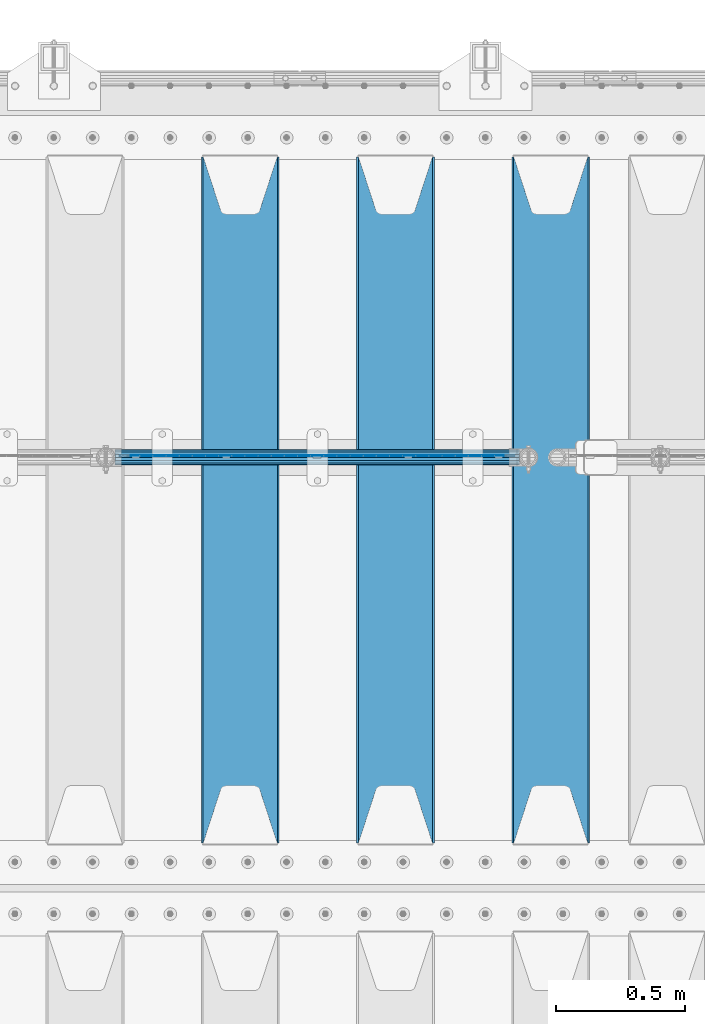
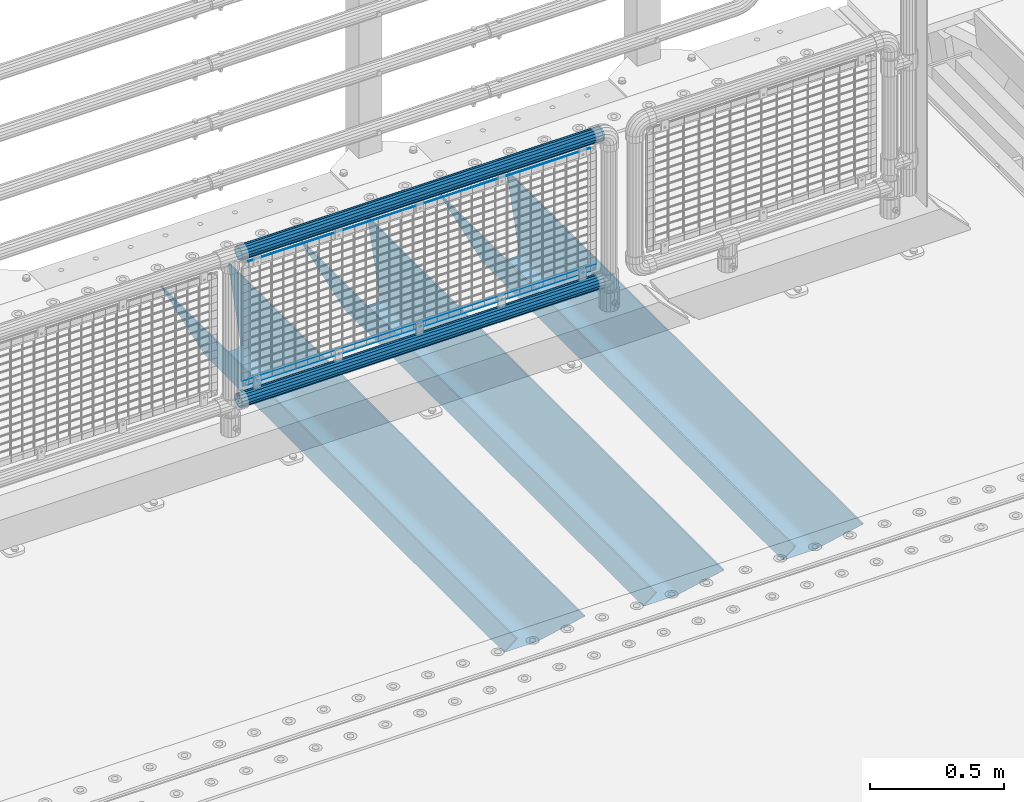
# One storey, part 134 of 242: 8 beams.
"""IFC2X3 building model written with IfcOpenShell, lengths in millimetres."""

from ifc_helpers import new_model, si_unit, frame, origin_with_axes, place, context, subcontext, project, spatial, faceted_brep, material, type_object, element, save


model = new_model("IFC2X3")

# Units and contexts
model_context = context("Model", 3, precision=1e-05, world=origin_with_axes())
body_context = subcontext(model_context, "Body", "Model", "MODEL_VIEW")
ifc_project = project(units=[si_unit("LENGTHUNIT", "METRE", prefix="MILLI"), si_unit("AREAUNIT", "SQUARE_METRE"), si_unit("VOLUMEUNIT", "CUBIC_METRE"), si_unit("MASSUNIT", "GRAM", prefix="KILO"), si_unit("TIMEUNIT", "SECOND"), si_unit("PLANEANGLEUNIT", "RADIAN"), si_unit("SOLIDANGLEUNIT", "STERADIAN"), si_unit("THERMODYNAMICTEMPERATUREUNIT", "DEGREE_CELSIUS"), si_unit("LUMINOUSINTENSITYUNIT", "LUMEN")], contexts=[model_context])

# Site, building, storey
site_placement = place(None, origin_with_axes())
site = spatial("IfcSite", under=ifc_project, at=site_placement, CompositionType="ELEMENT")
building_placement = place(site_placement, origin_with_axes())
building = spatial("IfcBuilding", under=site, at=building_placement, Name="Standard", CompositionType="ELEMENT")
storey_placement = place(building_placement, origin_with_axes())
storey = spatial("IfcBuildingStorey", under=building, at=storey_placement, Name="Undefined", CompositionType="ELEMENT", Elevation=0.0)

# Beams
ifc_material_1 = material(Name="Misc_Undefined")
beam_type_1 = type_object("IfcBeamType", Name="D3", PredefinedType="NOTDEFINED")
beam_1_placement = place(storey_placement, frame((-25419.0, -19329.5, 353.02), z_axis=(0.0, 0.0, 1.0), x_axis=(1.0, 0.0, 0.0)))
element("IfcBeam", 1, at=beam_1_placement, inside=storey, type_object=beam_type_1, material=ifc_material_1, ObjectType="D3", context=body_context, shape_type="Brep", body=[
    faceted_brep([(0.0, -1.50000000000364, 0.0), (-3.63797880709171e-12, -0.750000000003638, -1.29903810567669), (1473.0, -0.75, -1.29903810567669), (1473.0, -1.5, 0.0), (0.0, 0.749999999996362, -1.29903810567669), (1473.0, 0.75, -1.29903810567663), (-3.63797880709171e-12, 1.49999999999636, 0.0), (1473.0, 1.5, 0.0), (0.0, 0.749999999996362, 1.29903810567669), (1473.0, 0.75, 1.29903810567669), (-3.63797880709171e-12, -0.750000000003638, 1.29903810567669), (1473.0, -0.75, 1.29903810567669)], [[[0, 1, 2, 3]], [[1, 4, 5, 2]], [[4, 6, 7, 5]], [[6, 8, 9, 7]], [[8, 10, 11, 9]], [[10, 0, 3, 11]], [[5, 7, 9, 11, 3, 2]], [[10, 8, 6, 4, 1, 0]]]),
])
beam_2_placement = place(storey_placement, frame((-25444.0, -19329.5, 378.02), z_axis=(0.0, 0.0, 1.0), x_axis=(1.0, 0.0, 0.0)))
element("IfcBeam", 2, at=beam_2_placement, inside=storey, type_object=beam_type_1, material=ifc_material_1, ObjectType="D3", context=body_context, shape_type="Brep", body=[
    faceted_brep([(0.0, -1.50000000000364, 0.0), (-3.63797880709171e-12, -0.750000000003638, -1.29903810567669), (1523.0, -0.75, -1.29903810567669), (1523.0, -1.5, 0.0), (0.0, 0.749999999996362, -1.29903810567669), (1523.0, 0.75, -1.29903810567669), (-3.63797880709171e-12, 1.49999999999636, 0.0), (1523.0, 1.5, 0.0), (0.0, 0.749999999996362, 1.29903810567669), (1523.0, 0.75, 1.29903810567669), (-3.63797880709171e-12, -0.750000000003638, 1.29903810567669), (1523.0, -0.75, 1.29903810567669)], [[[0, 1, 2, 3]], [[1, 4, 5, 2]], [[4, 6, 7, 5]], [[6, 8, 9, 7]], [[8, 10, 11, 9]], [[10, 0, 3, 11]], [[5, 7, 9, 11, 3, 2]], [[10, 8, 6, 4, 1, 0]]]),
])
beam_3_placement = place(storey_placement, frame((-25419.0, -19329.5, 913.02), z_axis=(0.0, 0.0, 1.0), x_axis=(1.0, 0.0, 0.0)))
element("IfcBeam", 3, at=beam_3_placement, inside=storey, type_object=beam_type_1, material=ifc_material_1, ObjectType="D3", context=body_context, shape_type="Brep", body=[
    faceted_brep([(0.0, -1.50000000000364, 0.0), (-3.63797880709171e-12, -0.750000000003638, -1.29903810567669), (1473.0, -0.75, -1.29903810567669), (1473.0, -1.5, 0.0), (0.0, 0.749999999996362, -1.29903810567669), (1473.0, 0.75, -1.29903810567663), (-3.63797880709171e-12, 1.49999999999636, 0.0), (1473.0, 1.5, 0.0), (0.0, 0.749999999996362, 1.29903810567669), (1473.0, 0.75, 1.29903810567669), (-3.63797880709171e-12, -0.750000000003638, 1.29903810567669), (1473.0, -0.75, 1.29903810567669)], [[[0, 1, 2, 3]], [[1, 4, 5, 2]], [[4, 6, 7, 5]], [[6, 8, 9, 7]], [[8, 10, 11, 9]], [[10, 0, 3, 11]], [[5, 7, 9, 11, 3, 2]], [[10, 8, 6, 4, 1, 0]]]),
])
ifc_material_2 = material()
beam_type_2 = type_object("IfcBeamType", PredefinedType="NOTDEFINED")
beam_4_placement = place(storey_placement, frame((-25464.15, -19335.5, 969.849999999999), z_axis=(0.0, 0.0, 1.0), x_axis=(1.0, 0.0, 0.0)))
element("IfcBeam", 4, at=beam_4_placement, inside=storey, type_object=beam_type_2, material=ifc_material_2, context=body_context, shape_type="Brep", body=[
    faceted_brep([(0.0, -25.3499999999985, 0.0), (0.0, -23.4203461491597, 9.70102501045403), (1563.0, -23.4203461491597, 9.70102501045506), (1563.0, -25.3499999999985, 0.0), (0.0, -17.9251569030785, 17.9251569030785), (1563.0, -17.9251569030785, 17.925156903079), (0.0, -9.70102501045403, 23.4203461491597), (1563.0, -9.70102501045403, 23.4203461491611), (0.0, 0.0, 25.3499999999985), (1563.0, 0.0, 25.35), (0.0, 9.70102501045403, 23.4203461491597), (1563.0, 9.70102501045403, 23.4203461491611), (0.0, 17.9251569030785, 17.9251569030785), (1563.0, 17.9251569030785, 17.925156903079), (0.0, 23.4203461491597, 9.70102501045403), (1563.0, 23.4203461491597, 9.70102501045506), (0.0, 25.3499999999985, 0.0), (1563.0, 25.3499999999985, 0.0), (0.0, 23.4203461491597, -9.70102501045403), (1563.0, 23.4203461491597, -9.70102501045506), (0.0, 17.9251569030785, -17.9251569030785), (1563.0, 17.9251569030785, -17.925156903079), (0.0, 9.70102501045403, -23.4203461491597), (1563.0, 9.70102501045403, -23.4203461491611), (0.0, 0.0, -25.3499999999985), (1563.0, 0.0, -25.35), (0.0, -9.70102501045403, -23.4203461491597), (1563.0, -9.70102501045403, -23.4203461491611), (0.0, -17.9251569030785, -17.9251569030785), (1563.0, -17.9251569030785, -17.925156903079), (0.0, -23.4203461491597, -9.70102501045403), (1563.0, -23.4203461491597, -9.70102501045506), (0.0, -30.1500000000015, 0.0), (0.0, -27.8549679052157, -11.5379054858058), (1563.0, -27.8549679052157, -11.5379054858075), (1563.0, -30.1500000000015, 0.0), (0.0, -21.3192694527752, -21.3192694527752), (1563.0, -21.3192694527752, -21.3192694527744), (0.0, -11.5379054858058, -27.8549679052157), (1563.0, -11.5379054858058, -27.8549679052153), (0.0, 0.0, -30.1500000000015), (1563.0, 0.0, -30.15), (0.0, 11.5379054858058, -27.8549679052157), (1563.0, 11.5379054858058, -27.8549679052153), (0.0, 21.3192694527752, -21.3192694527752), (1563.0, 21.3192694527752, -21.3192694527744), (0.0, 27.8549679052157, -11.5379054858058), (1563.0, 27.8549679052157, -11.5379054858074), (0.0, 30.1500000000015, 0.0), (1563.0, 30.1500000000015, 0.0), (0.0, 27.8549679052157, 11.5379054858058), (1563.0, 27.8549679052157, 11.5379054858074), (0.0, 21.3192694527752, 21.3192694527752), (1563.0, 21.3192694527752, 21.3192694527744), (0.0, 11.5379054858058, 27.8549679052157), (1563.0, 11.5379054858058, 27.8549679052153), (0.0, 0.0, 30.1500000000015), (1563.0, 0.0, 30.15), (0.0, -11.5379054858058, 27.8549679052157), (1563.0, -11.5379054858058, 27.8549679052153), (0.0, -21.3192694527752, 21.3192694527752), (1563.0, -21.3192694527752, 21.3192694527744), (0.0, -27.8549679052157, 11.5379054858058), (1563.0, -27.8549679052157, 11.5379054858074)], [[[0, 1, 2, 3]], [[1, 4, 5, 2]], [[4, 6, 7, 5]], [[6, 8, 9, 7]], [[8, 10, 11, 9]], [[10, 12, 13, 11]], [[12, 14, 15, 13]], [[14, 16, 17, 15]], [[16, 18, 19, 17]], [[18, 20, 21, 19]], [[20, 22, 23, 21]], [[22, 24, 25, 23]], [[24, 26, 27, 25]], [[26, 28, 29, 27]], [[28, 30, 31, 29]], [[30, 0, 3, 31]], [[32, 33, 34, 35]], [[33, 36, 37, 34]], [[36, 38, 39, 37]], [[38, 40, 41, 39]], [[40, 42, 43, 41]], [[42, 44, 45, 43]], [[44, 46, 47, 45]], [[46, 48, 49, 47]], [[48, 50, 51, 49]], [[50, 52, 53, 51]], [[52, 54, 55, 53]], [[54, 56, 57, 55]], [[56, 58, 59, 57]], [[58, 60, 61, 59]], [[60, 62, 63, 61]], [[62, 32, 35, 63]], [[37, 39, 41, 43, 45, 47, 49, 51, 53, 55, 57, 59, 61, 63, 35, 34], [5, 7, 9, 11, 13, 15, 17, 19, 21, 23, 25, 27, 29, 31, 3, 2]], [[62, 60, 58, 56, 54, 52, 50, 48, 46, 44, 42, 40, 38, 36, 33, 32], [30, 28, 26, 24, 22, 20, 18, 16, 14, 12, 10, 8, 6, 4, 1, 0]]]),
])
beam_5_placement = place(storey_placement, frame((-25464.15, -19335.5, 298.170000000001), z_axis=(0.0, 0.0, 1.0), x_axis=(1.0, 0.0, 0.0)))
element("IfcBeam", 5, at=beam_5_placement, inside=storey, type_object=beam_type_2, material=ifc_material_2, context=body_context, shape_type="Brep", body=[
    faceted_brep([(0.0, -25.3499999999985, 0.0), (0.0, -23.4203461491597, 9.70102501045403), (1563.0, -23.4203461491597, 9.70102501045506), (1563.0, -25.3499999999985, 0.0), (0.0, -17.9251569030785, 17.9251569030785), (1563.0, -17.9251569030785, 17.925156903079), (0.0, -9.70102501045403, 23.4203461491597), (1563.0, -9.70102501045403, 23.4203461491611), (0.0, 0.0, 25.3499999999985), (1563.0, 0.0, 25.35), (0.0, 9.70102501045403, 23.4203461491597), (1563.0, 9.70102501045403, 23.4203461491611), (0.0, 17.9251569030785, 17.9251569030785), (1563.0, 17.9251569030785, 17.925156903079), (0.0, 23.4203461491597, 9.70102501045403), (1563.0, 23.4203461491597, 9.70102501045506), (0.0, 25.3499999999985, 0.0), (1563.0, 25.3499999999985, 0.0), (0.0, 23.4203461491597, -9.70102501045403), (1563.0, 23.4203461491597, -9.70102501045506), (0.0, 17.9251569030785, -17.9251569030785), (1563.0, 17.9251569030785, -17.925156903079), (0.0, 9.70102501045403, -23.4203461491597), (1563.0, 9.70102501045403, -23.4203461491611), (0.0, 0.0, -25.3499999999985), (1563.0, 0.0, -25.35), (0.0, -9.70102501045403, -23.4203461491597), (1563.0, -9.70102501045403, -23.4203461491611), (0.0, -17.9251569030785, -17.9251569030785), (1563.0, -17.9251569030785, -17.925156903079), (0.0, -23.4203461491597, -9.70102501045403), (1563.0, -23.4203461491597, -9.70102501045506), (0.0, -30.1500000000015, 0.0), (0.0, -27.8549679052157, -11.5379054858058), (1563.0, -27.8549679052157, -11.5379054858075), (1563.0, -30.1500000000015, 0.0), (0.0, -21.3192694527752, -21.3192694527752), (1563.0, -21.3192694527752, -21.3192694527744), (0.0, -11.5379054858058, -27.8549679052157), (1563.0, -11.5379054858058, -27.8549679052153), (0.0, 0.0, -30.1500000000015), (1563.0, 0.0, -30.15), (0.0, 11.5379054858058, -27.8549679052157), (1563.0, 11.5379054858058, -27.8549679052153), (0.0, 21.3192694527752, -21.3192694527752), (1563.0, 21.3192694527752, -21.3192694527744), (0.0, 27.8549679052157, -11.5379054858058), (1563.0, 27.8549679052157, -11.5379054858074), (0.0, 30.1500000000015, 0.0), (1563.0, 30.1500000000015, 0.0), (0.0, 27.8549679052157, 11.5379054858058), (1563.0, 27.8549679052157, 11.5379054858074), (0.0, 21.3192694527752, 21.3192694527752), (1563.0, 21.3192694527752, 21.3192694527744), (0.0, 11.5379054858058, 27.8549679052157), (1563.0, 11.5379054858058, 27.8549679052153), (0.0, 0.0, 30.1500000000015), (1563.0, 0.0, 30.15), (0.0, -11.5379054858058, 27.8549679052157), (1563.0, -11.5379054858058, 27.8549679052153), (0.0, -21.3192694527752, 21.3192694527752), (1563.0, -21.3192694527752, 21.3192694527744), (0.0, -27.8549679052157, 11.5379054858058), (1563.0, -27.8549679052157, 11.5379054858074)], [[[0, 1, 2, 3]], [[1, 4, 5, 2]], [[4, 6, 7, 5]], [[6, 8, 9, 7]], [[8, 10, 11, 9]], [[10, 12, 13, 11]], [[12, 14, 15, 13]], [[14, 16, 17, 15]], [[16, 18, 19, 17]], [[18, 20, 21, 19]], [[20, 22, 23, 21]], [[22, 24, 25, 23]], [[24, 26, 27, 25]], [[26, 28, 29, 27]], [[28, 30, 31, 29]], [[30, 0, 3, 31]], [[32, 33, 34, 35]], [[33, 36, 37, 34]], [[36, 38, 39, 37]], [[38, 40, 41, 39]], [[40, 42, 43, 41]], [[42, 44, 45, 43]], [[44, 46, 47, 45]], [[46, 48, 49, 47]], [[48, 50, 51, 49]], [[50, 52, 53, 51]], [[52, 54, 55, 53]], [[54, 56, 57, 55]], [[56, 58, 59, 57]], [[58, 60, 61, 59]], [[60, 62, 63, 61]], [[62, 32, 35, 63]], [[37, 39, 41, 43, 45, 47, 49, 51, 53, 55, 57, 59, 61, 63, 35, 34], [5, 7, 9, 11, 13, 15, 17, 19, 21, 23, 25, 27, 29, 31, 3, 2]], [[62, 60, 58, 56, 54, 52, 50, 48, 46, 44, 42, 40, 38, 36, 33, 32], [30, 28, 26, 24, 22, 20, 18, 16, 14, 12, 10, 8, 6, 4, 1, 0]]]),
])
ifc_material_3 = material(Name="STEEL/S355N")
beam_type_3 = type_object("IfcBeamType", PredefinedType="NOTDEFINED")
beam_6_placement = place(storey_placement, frame((-23780.0, -20825.0, -115.0), z_axis=(0.0, 0.0, 1.0), x_axis=(0.0, 1.0, 0.0)))
element("IfcBeam", 6, at=beam_6_placement, inside=storey, type_object=beam_type_3, material=ifc_material_3, context=body_context, shape_type="Brep", body=[
    faceted_brep([(0.0, 150.0, 115.0), (0.0, 143.689999999999, 115.0), (2650.00000000297, 143.689999999999, 115.0), (2650.00000000297, 150.0, 115.0), (2650.00000000297, 142.059565218402, 110.000000003099), (2650.00000000297, 148.369565218403, 110.000000003099), (2441.90079219209, -80.1103600731112, -98.0992078077845), (2437.7588105432, -77.5672621345584, -102.241189456673), (2434.06523489747, -74.4080125315522, -105.934765102404), (2430.91086095089, -70.710272125576, -109.089139048974), (2428.37322971128, -66.5649389910068, -111.626770288588), (2426.51472138055, -62.0739139532889, -113.485278619323), (2425.38102192092, -57.3475956567672, -114.618978078955), (2424.99999999987, -52.5021667386536, -115.0), (2424.99999999987, 52.5021667386536, -115.0), (2425.38102192092, 57.3475956567672, -114.618978078955), (2426.51472138055, 62.0739139532889, -113.485278619323), (2428.37322971128, 66.5649389910068, -111.626770288588), (2430.91086095089, 70.710272125576, -109.089139048974), (2434.06523489747, 74.4080125315522, -105.934765102404), (2437.7588105432, 77.5672621345584, -102.241189456673), (2441.90079219209, 80.1103600731112, -98.0992078077846), (2446.38936140511, 81.9747917625791, -93.6106385947584), (2448.2494850041, 76.2713538057251, -91.7505149957729), (2444.62967112262, 74.76777986261, -95.3703288772456), (2441.28936334126, 72.7168944282894, -98.710636658607), (2438.31067330438, 70.1691124903846, -101.689326695487), (2435.76682334747, 67.1870637758839, -104.233176652398), (2433.72034654133, 63.8440531834895, -106.279653458539), (2432.22154950042, 60.222258798236, -107.778450499454), (2431.30727574265, 56.4107117849089, -108.692724257221), (2430.99999999987, 52.5031078186876, -109.0), (2430.99999999987, -52.5031078186876, -109.0), (2431.30727574265, -56.4107117849089, -108.692724257221), (2432.22154950042, -60.222258798236, -107.778450499454), (2433.72034654133, -63.8440531834895, -106.279653458539), (2435.76682334747, -67.1870637758839, -104.233176652398), (2438.31067330438, -70.1691124903846, -101.689326695487), (2441.28936334126, -72.7168944282894, -98.7106366586071), (2444.62967112262, -74.76777986261, -95.3703288772457), (2448.2494850041, -76.2713538057251, -91.7505149957729), (2650.00000000297, -142.059565218402, 110.000000003099), (2650.00000000297, -148.369565218403, 110.000000003099), (2446.38936140511, -81.9747917625791, -93.6106385947584), (2650.00000000297, -143.689999999999, 115.0), (2650.00000000297, -150.0, 115.0), (0.0, -143.689999999999, 115.0), (0.0, -150.0, 115.0), (0.0, -148.369565218261, 110.000000002669), (203.610638597427, -81.9747917625791, -93.6106385947584), (208.099207810454, -80.1103600731112, -98.0992078077845), (212.241189459342, -77.5672621345584, -102.241189456673), (215.934765105074, -74.4080125315522, -105.934765102404), (219.089139051644, -70.710272125576, -109.089139048974), (221.626770291256, -66.5649389910068, -111.626770288588), (223.485278621993, -62.0739139532889, -113.485278619323), (224.618978081624, -57.3475956567672, -114.618978078955), (225.00000000267, -52.5021667386536, -115.0), (225.00000000267, 52.5021667386536, -115.0), (224.618978081624, 57.3475956567672, -114.618978078955), (223.485278621993, 62.0739139532889, -113.485278619323), (221.626770291256, 66.5649389910068, -111.626770288588), (219.089139051644, 70.710272125576, -109.089139048974), (215.934765105074, 74.4080125315522, -105.934765102404), (212.241189459342, 77.5672621345584, -102.241189456673), (208.099207810454, 80.1103600731112, -98.0992078077846), (203.610638597427, 81.9747917625791, -93.6106385947584), (0.0, 148.369565218261, 110.000000002669), (0.0, 142.05956521826, 110.000000002669), (201.750514998443, 76.2713538057251, -91.7505149957729), (205.370328879915, 74.76777986261, -95.3703288772456), (208.710636661275, 72.7168944282894, -98.710636658607), (211.689326698157, 70.1691124903846, -101.689326695487), (214.233176655067, 67.1870637758839, -104.233176652398), (216.279653461206, 63.8440531834895, -106.279653458539), (217.778450502123, 60.222258798236, -107.778450499454), (218.69272425989, 56.4107117849089, -108.692724257221), (219.00000000267, 52.5031078186876, -109.0), (219.00000000267, -52.5031078186876, -109.0), (218.69272425989, -56.4107117849089, -108.692724257221), (217.778450502123, -60.222258798236, -107.778450499454), (216.279653461206, -63.8440531834895, -106.279653458539), (214.233176655067, -67.1870637758839, -104.233176652398), (211.689326698157, -70.1691124903846, -101.689326695487), (208.710636661275, -72.7168944282894, -98.7106366586071), (205.370328879915, -74.76777986261, -95.3703288772457), (201.750514998443, -76.2713538057251, -91.7505149957729), (0.0, -142.05956521826, 110.000000002669)], [[[0, 1, 2, 3]], [[3, 2, 4, 5]], [[6, 7, 8, 9, 10, 11, 12, 13, 14, 15, 16, 17, 18, 19, 20, 21, 22, 5, 4, 23, 24, 25, 26, 27, 28, 29, 30, 31, 32, 33, 34, 35, 36, 37, 38, 39, 40, 41, 42, 43]], [[44, 45, 42, 41]], [[46, 47, 45, 44]], [[43, 42, 45, 47, 48, 49]], [[6, 43, 49, 50]], [[7, 6, 50, 51]], [[8, 7, 51, 52]], [[9, 8, 52, 53]], [[10, 9, 53, 54]], [[11, 10, 54, 55]], [[12, 11, 55, 56]], [[13, 12, 56, 57]], [[14, 13, 57, 58]], [[15, 14, 58, 59]], [[16, 15, 59, 60]], [[17, 16, 60, 61]], [[18, 17, 61, 62]], [[19, 18, 62, 63]], [[20, 19, 63, 64]], [[21, 20, 64, 65]], [[22, 21, 65, 66]], [[0, 3, 5, 22, 66, 67]], [[1, 0, 67, 68]], [[23, 4, 2, 1, 68, 69]], [[24, 23, 69, 70]], [[25, 24, 70, 71]], [[26, 25, 71, 72]], [[27, 26, 72, 73]], [[28, 27, 73, 74]], [[29, 28, 74, 75]], [[30, 29, 75, 76]], [[31, 30, 76, 77]], [[32, 31, 77, 78]], [[33, 32, 78, 79]], [[34, 33, 79, 80]], [[35, 34, 80, 81]], [[36, 35, 81, 82]], [[37, 36, 82, 83]], [[38, 37, 83, 84]], [[39, 38, 84, 85]], [[40, 39, 85, 86]], [[46, 44, 41, 40, 86, 87]], [[47, 46, 87, 48]], [[86, 85, 84, 83, 82, 81, 80, 79, 78, 77, 76, 75, 74, 73, 72, 71, 70, 69, 68, 67, 66, 65, 64, 63, 62, 61, 60, 59, 58, 57, 56, 55, 54, 53, 52, 51, 50, 49, 48, 87]]]),
])
beam_7_placement = place(storey_placement, frame((-24380.0, -20825.0, -115.0), z_axis=(0.0, 0.0, 1.0), x_axis=(0.0, 1.0, 0.0)))
element("IfcBeam", 7, at=beam_7_placement, inside=storey, type_object=beam_type_3, material=ifc_material_3, context=body_context, shape_type="Brep", body=[
    faceted_brep([(0.0, 150.0, 115.0), (0.0, 143.689999999999, 115.0), (2650.00000000297, 143.689999999999, 115.0), (2650.00000000297, 150.0, 115.0), (2650.00000000297, 142.059565218402, 110.000000003099), (2650.00000000297, 148.369565218403, 110.000000003099), (2441.90079219209, -80.1103600731112, -98.0992078077845), (2437.7588105432, -77.5672621345584, -102.241189456673), (2434.06523489747, -74.4080125315522, -105.934765102404), (2430.91086095089, -70.710272125576, -109.089139048974), (2428.37322971128, -66.5649389910068, -111.626770288588), (2426.51472138055, -62.0739139532889, -113.485278619323), (2425.38102192092, -57.3475956567672, -114.618978078955), (2424.99999999987, -52.5021667386536, -115.0), (2424.99999999987, 52.5021667386536, -115.0), (2425.38102192092, 57.3475956567672, -114.618978078955), (2426.51472138055, 62.0739139532889, -113.485278619323), (2428.37322971128, 66.5649389910068, -111.626770288588), (2430.91086095089, 70.710272125576, -109.089139048974), (2434.06523489747, 74.4080125315522, -105.934765102404), (2437.7588105432, 77.5672621345584, -102.241189456673), (2441.90079219209, 80.1103600731112, -98.0992078077846), (2446.38936140511, 81.9747917625791, -93.6106385947584), (2448.2494850041, 76.2713538057251, -91.7505149957729), (2444.62967112262, 74.76777986261, -95.3703288772456), (2441.28936334126, 72.7168944282894, -98.710636658607), (2438.31067330438, 70.1691124903846, -101.689326695487), (2435.76682334747, 67.1870637758839, -104.233176652398), (2433.72034654133, 63.8440531834895, -106.279653458539), (2432.22154950042, 60.222258798236, -107.778450499454), (2431.30727574265, 56.4107117849089, -108.692724257221), (2430.99999999987, 52.5031078186876, -109.0), (2430.99999999987, -52.5031078186876, -109.0), (2431.30727574265, -56.4107117849089, -108.692724257221), (2432.22154950042, -60.222258798236, -107.778450499454), (2433.72034654133, -63.8440531834895, -106.279653458539), (2435.76682334747, -67.1870637758839, -104.233176652398), (2438.31067330438, -70.1691124903846, -101.689326695487), (2441.28936334126, -72.7168944282894, -98.7106366586071), (2444.62967112262, -74.76777986261, -95.3703288772457), (2448.2494850041, -76.2713538057251, -91.7505149957729), (2650.00000000297, -142.059565218402, 110.000000003099), (2650.00000000297, -148.369565218403, 110.000000003099), (2446.38936140511, -81.9747917625791, -93.6106385947584), (2650.00000000297, -143.689999999999, 115.0), (2650.00000000297, -150.0, 115.0), (0.0, -143.689999999999, 115.0), (0.0, -150.0, 115.0), (0.0, -148.369565218261, 110.000000002669), (203.610638597427, -81.9747917625791, -93.6106385947584), (208.099207810454, -80.1103600731112, -98.0992078077845), (212.241189459342, -77.5672621345584, -102.241189456673), (215.934765105074, -74.4080125315522, -105.934765102404), (219.089139051644, -70.710272125576, -109.089139048974), (221.626770291256, -66.5649389910068, -111.626770288588), (223.485278621993, -62.0739139532889, -113.485278619323), (224.618978081624, -57.3475956567672, -114.618978078955), (225.00000000267, -52.5021667386536, -115.0), (225.00000000267, 52.5021667386536, -115.0), (224.618978081624, 57.3475956567672, -114.618978078955), (223.485278621993, 62.0739139532889, -113.485278619323), (221.626770291256, 66.5649389910068, -111.626770288588), (219.089139051644, 70.710272125576, -109.089139048974), (215.934765105074, 74.4080125315522, -105.934765102404), (212.241189459342, 77.5672621345584, -102.241189456673), (208.099207810454, 80.1103600731112, -98.0992078077846), (203.610638597427, 81.9747917625791, -93.6106385947584), (0.0, 148.369565218261, 110.000000002669), (0.0, 142.05956521826, 110.000000002669), (201.750514998443, 76.2713538057251, -91.7505149957729), (205.370328879915, 74.76777986261, -95.3703288772456), (208.710636661275, 72.7168944282894, -98.710636658607), (211.689326698157, 70.1691124903846, -101.689326695487), (214.233176655067, 67.1870637758839, -104.233176652398), (216.279653461206, 63.8440531834895, -106.279653458539), (217.778450502123, 60.222258798236, -107.778450499454), (218.69272425989, 56.4107117849089, -108.692724257221), (219.00000000267, 52.5031078186876, -109.0), (219.00000000267, -52.5031078186876, -109.0), (218.69272425989, -56.4107117849089, -108.692724257221), (217.778450502123, -60.222258798236, -107.778450499454), (216.279653461206, -63.8440531834895, -106.279653458539), (214.233176655067, -67.1870637758839, -104.233176652398), (211.689326698157, -70.1691124903846, -101.689326695487), (208.710636661275, -72.7168944282894, -98.7106366586071), (205.370328879915, -74.76777986261, -95.3703288772457), (201.750514998443, -76.2713538057251, -91.7505149957729), (0.0, -142.05956521826, 110.000000002669)], [[[0, 1, 2, 3]], [[3, 2, 4, 5]], [[6, 7, 8, 9, 10, 11, 12, 13, 14, 15, 16, 17, 18, 19, 20, 21, 22, 5, 4, 23, 24, 25, 26, 27, 28, 29, 30, 31, 32, 33, 34, 35, 36, 37, 38, 39, 40, 41, 42, 43]], [[44, 45, 42, 41]], [[46, 47, 45, 44]], [[43, 42, 45, 47, 48, 49]], [[6, 43, 49, 50]], [[7, 6, 50, 51]], [[8, 7, 51, 52]], [[9, 8, 52, 53]], [[10, 9, 53, 54]], [[11, 10, 54, 55]], [[12, 11, 55, 56]], [[13, 12, 56, 57]], [[14, 13, 57, 58]], [[15, 14, 58, 59]], [[16, 15, 59, 60]], [[17, 16, 60, 61]], [[18, 17, 61, 62]], [[19, 18, 62, 63]], [[20, 19, 63, 64]], [[21, 20, 64, 65]], [[22, 21, 65, 66]], [[0, 3, 5, 22, 66, 67]], [[1, 0, 67, 68]], [[23, 4, 2, 1, 68, 69]], [[24, 23, 69, 70]], [[25, 24, 70, 71]], [[26, 25, 71, 72]], [[27, 26, 72, 73]], [[28, 27, 73, 74]], [[29, 28, 74, 75]], [[30, 29, 75, 76]], [[31, 30, 76, 77]], [[32, 31, 77, 78]], [[33, 32, 78, 79]], [[34, 33, 79, 80]], [[35, 34, 80, 81]], [[36, 35, 81, 82]], [[37, 36, 82, 83]], [[38, 37, 83, 84]], [[39, 38, 84, 85]], [[40, 39, 85, 86]], [[46, 44, 41, 40, 86, 87]], [[47, 46, 87, 48]], [[86, 85, 84, 83, 82, 81, 80, 79, 78, 77, 76, 75, 74, 73, 72, 71, 70, 69, 68, 67, 66, 65, 64, 63, 62, 61, 60, 59, 58, 57, 56, 55, 54, 53, 52, 51, 50, 49, 48, 87]]]),
])
beam_8_placement = place(storey_placement, frame((-24980.0, -20825.0, -115.0), z_axis=(0.0, 0.0, 1.0), x_axis=(0.0, 1.0, 0.0)))
element("IfcBeam", 8, at=beam_8_placement, inside=storey, type_object=beam_type_3, material=ifc_material_3, context=body_context, shape_type="Brep", body=[
    faceted_brep([(0.0, 150.0, 115.0), (0.0, 143.689999999999, 115.0), (2650.00000000297, 143.689999999999, 115.0), (2650.00000000297, 150.0, 115.0), (2650.00000000297, 142.059565218402, 110.000000003099), (2650.00000000297, 148.369565218403, 110.000000003099), (2441.90079219209, -80.1103600731112, -98.0992078077845), (2437.7588105432, -77.5672621345584, -102.241189456673), (2434.06523489747, -74.4080125315522, -105.934765102404), (2430.91086095089, -70.710272125576, -109.089139048974), (2428.37322971128, -66.5649389910068, -111.626770288588), (2426.51472138055, -62.0739139532889, -113.485278619323), (2425.38102192092, -57.3475956567672, -114.618978078955), (2424.99999999987, -52.5021667386536, -115.0), (2424.99999999987, 52.5021667386536, -115.0), (2425.38102192092, 57.3475956567672, -114.618978078955), (2426.51472138055, 62.0739139532889, -113.485278619323), (2428.37322971128, 66.5649389910068, -111.626770288588), (2430.91086095089, 70.710272125576, -109.089139048974), (2434.06523489747, 74.4080125315522, -105.934765102404), (2437.7588105432, 77.5672621345584, -102.241189456673), (2441.90079219209, 80.1103600731112, -98.0992078077846), (2446.38936140511, 81.9747917625791, -93.6106385947584), (2448.2494850041, 76.2713538057251, -91.7505149957729), (2444.62967112262, 74.76777986261, -95.3703288772456), (2441.28936334126, 72.7168944282894, -98.710636658607), (2438.31067330438, 70.1691124903846, -101.689326695487), (2435.76682334747, 67.1870637758839, -104.233176652398), (2433.72034654133, 63.8440531834895, -106.279653458539), (2432.22154950042, 60.222258798236, -107.778450499454), (2431.30727574265, 56.4107117849089, -108.692724257221), (2430.99999999987, 52.5031078186876, -109.0), (2430.99999999987, -52.5031078186876, -109.0), (2431.30727574265, -56.4107117849089, -108.692724257221), (2432.22154950042, -60.222258798236, -107.778450499454), (2433.72034654133, -63.8440531834895, -106.279653458539), (2435.76682334747, -67.1870637758839, -104.233176652398), (2438.31067330438, -70.1691124903846, -101.689326695487), (2441.28936334126, -72.7168944282894, -98.7106366586071), (2444.62967112262, -74.76777986261, -95.3703288772457), (2448.2494850041, -76.2713538057251, -91.7505149957729), (2650.00000000297, -142.059565218402, 110.000000003099), (2650.00000000297, -148.369565218403, 110.000000003099), (2446.38936140511, -81.9747917625791, -93.6106385947584), (2650.00000000297, -143.689999999999, 115.0), (2650.00000000297, -150.0, 115.0), (0.0, -143.689999999999, 115.0), (0.0, -150.0, 115.0), (0.0, -148.369565218261, 110.000000002669), (203.610638597427, -81.9747917625791, -93.6106385947584), (208.099207810454, -80.1103600731112, -98.0992078077845), (212.241189459342, -77.5672621345584, -102.241189456673), (215.934765105074, -74.4080125315522, -105.934765102404), (219.089139051644, -70.710272125576, -109.089139048974), (221.626770291256, -66.5649389910068, -111.626770288588), (223.485278621993, -62.0739139532889, -113.485278619323), (224.618978081624, -57.3475956567672, -114.618978078955), (225.00000000267, -52.5021667386536, -115.0), (225.00000000267, 52.5021667386536, -115.0), (224.618978081624, 57.3475956567672, -114.618978078955), (223.485278621993, 62.0739139532889, -113.485278619323), (221.626770291256, 66.5649389910068, -111.626770288588), (219.089139051644, 70.710272125576, -109.089139048974), (215.934765105074, 74.4080125315522, -105.934765102404), (212.241189459342, 77.5672621345584, -102.241189456673), (208.099207810454, 80.1103600731112, -98.0992078077846), (203.610638597427, 81.9747917625791, -93.6106385947584), (0.0, 148.369565218261, 110.000000002669), (0.0, 142.05956521826, 110.000000002669), (201.750514998443, 76.2713538057251, -91.7505149957729), (205.370328879915, 74.76777986261, -95.3703288772456), (208.710636661275, 72.7168944282894, -98.710636658607), (211.689326698157, 70.1691124903846, -101.689326695487), (214.233176655067, 67.1870637758839, -104.233176652398), (216.279653461206, 63.8440531834895, -106.279653458539), (217.778450502123, 60.222258798236, -107.778450499454), (218.69272425989, 56.4107117849089, -108.692724257221), (219.00000000267, 52.5031078186876, -109.0), (219.00000000267, -52.5031078186876, -109.0), (218.69272425989, -56.4107117849089, -108.692724257221), (217.778450502123, -60.222258798236, -107.778450499454), (216.279653461206, -63.8440531834895, -106.279653458539), (214.233176655067, -67.1870637758839, -104.233176652398), (211.689326698157, -70.1691124903846, -101.689326695487), (208.710636661275, -72.7168944282894, -98.7106366586071), (205.370328879915, -74.76777986261, -95.3703288772457), (201.750514998443, -76.2713538057251, -91.7505149957729), (0.0, -142.05956521826, 110.000000002669)], [[[0, 1, 2, 3]], [[3, 2, 4, 5]], [[6, 7, 8, 9, 10, 11, 12, 13, 14, 15, 16, 17, 18, 19, 20, 21, 22, 5, 4, 23, 24, 25, 26, 27, 28, 29, 30, 31, 32, 33, 34, 35, 36, 37, 38, 39, 40, 41, 42, 43]], [[44, 45, 42, 41]], [[46, 47, 45, 44]], [[43, 42, 45, 47, 48, 49]], [[6, 43, 49, 50]], [[7, 6, 50, 51]], [[8, 7, 51, 52]], [[9, 8, 52, 53]], [[10, 9, 53, 54]], [[11, 10, 54, 55]], [[12, 11, 55, 56]], [[13, 12, 56, 57]], [[14, 13, 57, 58]], [[15, 14, 58, 59]], [[16, 15, 59, 60]], [[17, 16, 60, 61]], [[18, 17, 61, 62]], [[19, 18, 62, 63]], [[20, 19, 63, 64]], [[21, 20, 64, 65]], [[22, 21, 65, 66]], [[0, 3, 5, 22, 66, 67]], [[1, 0, 67, 68]], [[23, 4, 2, 1, 68, 69]], [[24, 23, 69, 70]], [[25, 24, 70, 71]], [[26, 25, 71, 72]], [[27, 26, 72, 73]], [[28, 27, 73, 74]], [[29, 28, 74, 75]], [[30, 29, 75, 76]], [[31, 30, 76, 77]], [[32, 31, 77, 78]], [[33, 32, 78, 79]], [[34, 33, 79, 80]], [[35, 34, 80, 81]], [[36, 35, 81, 82]], [[37, 36, 82, 83]], [[38, 37, 83, 84]], [[39, 38, 84, 85]], [[40, 39, 85, 86]], [[46, 44, 41, 40, 86, 87]], [[47, 46, 87, 48]], [[86, 85, 84, 83, 82, 81, 80, 79, 78, 77, 76, 75, 74, 73, 72, 71, 70, 69, 68, 67, 66, 65, 64, 63, 62, 61, 60, 59, 58, 57, 56, 55, 54, 53, 52, 51, 50, 49, 48, 87]]]),
])

save(model, "model.ifc")
